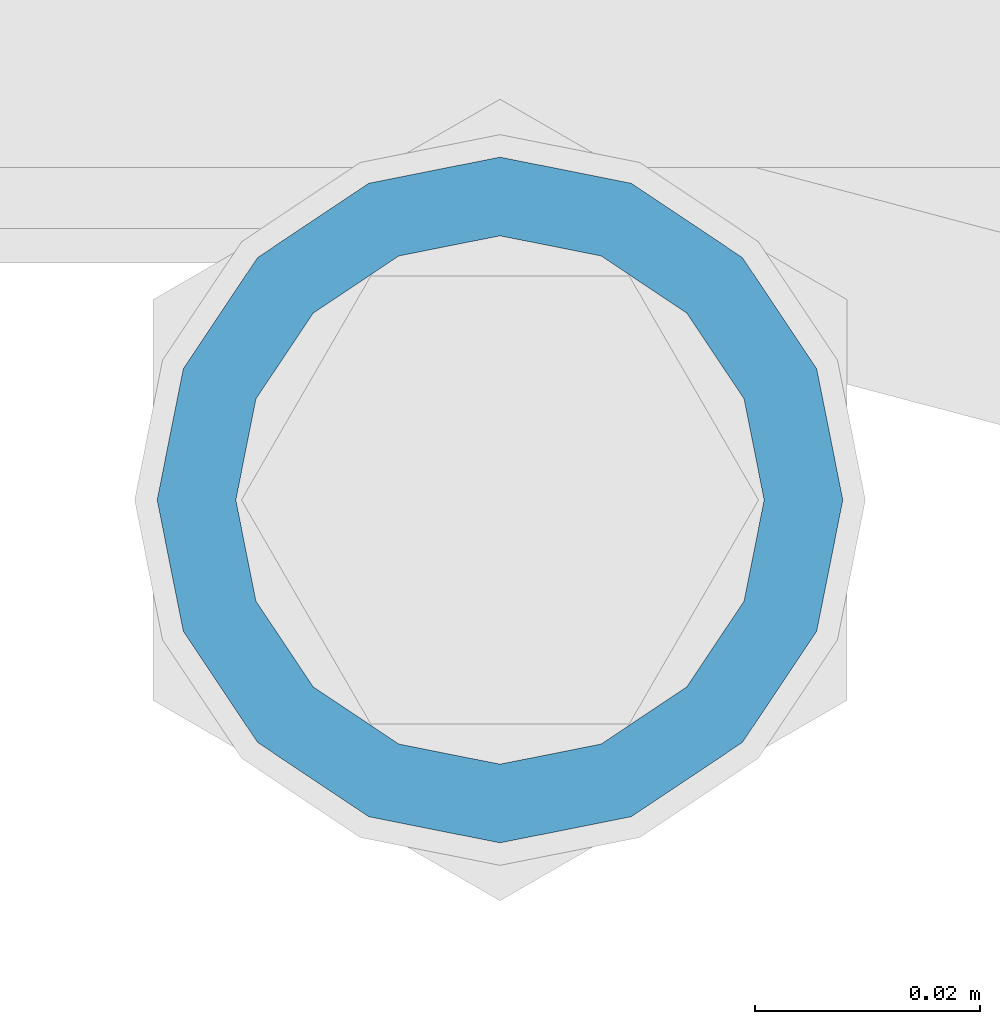
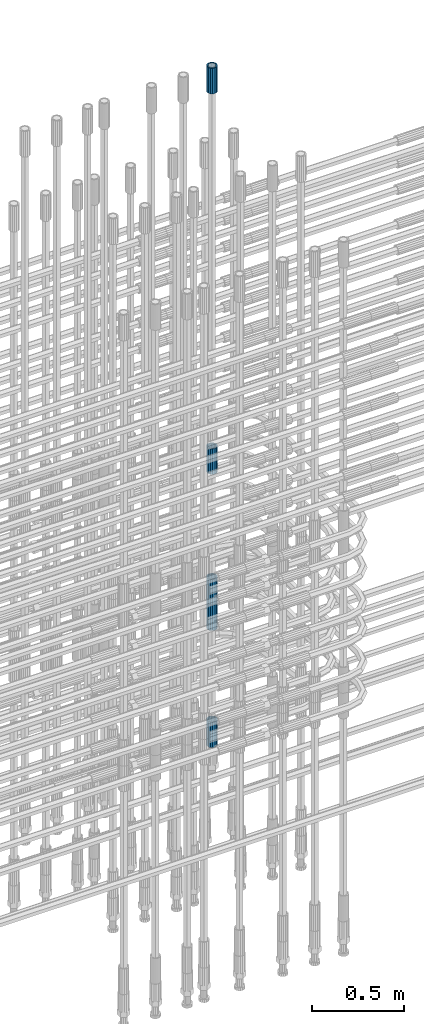
# One storey, part 73 of 119: 5 beams.
"""IFC2X3 building model written with IfcOpenShell, lengths in millimetres."""

from ifc_helpers import new_model, si_unit, frame, origin_with_axes, place, context, subcontext, project, spatial, faceted_brep, material, type_object, element, save


model = new_model("IFC2X3")

# Units and contexts
model_context = context("Model", 3, precision=1e-05, world=origin_with_axes())
body_context = subcontext(model_context, "Body", "Model", "MODEL_VIEW")
ifc_project = project(units=[si_unit("LENGTHUNIT", "METRE", prefix="MILLI"), si_unit("AREAUNIT", "SQUARE_METRE"), si_unit("VOLUMEUNIT", "CUBIC_METRE"), si_unit("MASSUNIT", "GRAM", prefix="KILO"), si_unit("TIMEUNIT", "SECOND"), si_unit("PLANEANGLEUNIT", "RADIAN"), si_unit("SOLIDANGLEUNIT", "STERADIAN"), si_unit("THERMODYNAMICTEMPERATUREUNIT", "DEGREE_CELSIUS"), si_unit("LUMINOUSINTENSITYUNIT", "LUMEN")], contexts=[model_context])

# Site, building, storey
site_placement = place(None, origin_with_axes())
site = spatial("IfcSite", under=ifc_project, at=site_placement, CompositionType="ELEMENT")
building_placement = place(site_placement, origin_with_axes())
building = spatial("IfcBuilding", under=site, at=building_placement, Name="Undefined", CompositionType="ELEMENT")
storey_placement = place(building_placement, origin_with_axes())
storey = spatial("IfcBuildingStorey", under=building, at=storey_placement, Name="Undefined", CompositionType="ELEMENT", Elevation=0.0)

# Beams
ifc_material = material(Name="STEEL/S275")
beam_type = type_object("IfcBeamType", PredefinedType="NOTDEFINED")
beam_1_placement = place(storey_placement, frame((2036305.58866833, 6206235.98579162, 20007.7168583141), z_axis=(-0.99999999999998, 1.98000110685822e-07, 0.0), x_axis=(0.0, 0.0, -1.0)))
element("IfcBeam", 1, at=beam_1_placement, inside=storey, type_object=beam_type, material=ifc_material, Name="AG40N", context=body_context, shape_type="Brep", body=[
    faceted_brep([(1.62981450557709e-09, -23.4999999990687, 0.0), (7.45058059692383e-09, -21.7111690142192, 8.99306066057534), (170.000002125278, -21.711168999318, 8.99306066022245), (170.000002127141, -23.4999999844003, -3.66071617463604e-10), (4.65661287307739e-09, -16.6170093587134, 16.6170093578889), (170.000002122484, -16.6170093440451, 16.6170093575288), (1.86264514923096e-09, -8.99306066217832, 21.7111690140277), (170.000002118759, -8.99306064750999, 21.7111690136603), (2.3283064365387e-10, 9.31322574615479e-10, 23.5), (170.000002114102, 1.28056854009628e-08, 23.4999999996485), (-6.51925802230835e-09, 8.99306065868586, 21.7111690140241), (170.00000211224, 8.99306067335419, 21.7111690136639), (-7.45058059692383e-09, 16.6170093561523, 16.6170093578853), (170.000002109446, 16.6170093708206, 16.6170093575324), (-9.31322574615479e-09, 21.711169013055, 8.99306066057534), (170.000002108514, 21.7111690277234, 8.99306066022245), (-1.16415321826935e-09, 23.5000000009313, 0.0), (170.000002108514, 23.5000000144355, -3.66071617463604e-10), (-8.38190317153931e-09, 21.7111690151505, -8.99306066059444), (170.000002110377, 21.7111690300517, -8.9930606609546), (-5.58793544769287e-09, 16.6170093598776, -16.6170093579008), (170.000002113171, 16.6170093745459, -16.6170093582609), (-9.31322574615479e-10, 8.99306066334248, -21.7111690140396), (170.000002115965, 8.99306067801081, -21.7111690143961), (2.3283064365387e-10, 9.31322574615479e-10, -23.5), (170.00000211969, 1.7927959561348e-08, -23.5000000003843), (5.58793544769287e-09, -8.99306065752171, -21.7111690140396), (170.000002123415, -8.99306064285338, -21.7111690143961), (8.38190317153931e-09, -16.6170093549881, -16.6170093579008), (170.000002125278, -16.6170093403198, -16.6170093582646), (9.31322574615479e-09, -21.7111690121237, -8.99306066059444), (170.000002127141, -21.7111689972226, -8.9930606609546), (1.11758708953857e-08, -30.4999999990687, -9.54969436861575e-12), (1.30385160446167e-08, -28.1783257392235, -11.6718446871514), (170.000002129003, -28.1783257243223, -11.6718446875116), (170.000002129935, -30.4999999841675, -3.66071617463604e-10), (1.02445483207703e-08, -21.5667568228673, -21.5667568262129), (170.000002128072, -21.566756808199, -21.5667568265694), (7.45058059692383e-09, -11.6718446831219, -28.1783257416196), (170.000002125278, -11.6718446684536, -28.1783257419834), (3.72529029846191e-09, 3.95812094211578e-09, -30.5000000000277), (170.00000211969, 1.83936208486557e-08, -30.5000000003879), (-9.31322574615479e-10, 11.6718446905725, -28.1783257416232), (170.000002115965, 11.6718447052408, -28.1783257419797), (-6.51925802230835e-09, 21.5667568286881, -21.5667568262093), (170.000002110377, 21.5667568433564, -21.5667568265694), (-9.31322574615479e-09, 28.178325742716, -11.6718446871478), (170.000002108514, 28.1783257573843, -11.6718446875079), (-1.21071934700012e-08, 30.5, -5.91171556152403e-12), (170.000002106652, 30.5000000144355, -3.62433638656512e-10), (-1.21071934700012e-08, 28.1783257401548, 11.6718446871359), (170.00000210572, 28.1783257548232, 11.6718446867794), (-1.02445483207703e-08, 21.5667568240315, 21.5667568261974), (170.000002107583, 21.566756838467, 21.5667568258409), (-7.45058059692383e-09, 11.671844684286, 28.1783257416041), (170.000002110377, 11.6718446989544, 28.178325741244), (-2.79396772384644e-09, -2.56113708019257e-09, 30.5000000000159), (170.000002114102, 1.18743628263474e-08, 30.4999999996558), (1.86264514923096e-09, -11.6718446896411, 28.1783257416114), (170.000002118759, -11.67184467474, 28.178325741244), (7.45058059692383e-09, -21.5667568275239, 21.5667568261974), (170.000002123415, -21.5667568126228, 21.5667568258373), (1.02445483207703e-08, -28.1783257415518, 11.6718446871359), (170.000002127141, -28.1783257271163, 11.6718446867794)], [[[0, 1, 2, 3]], [[1, 4, 5, 2]], [[4, 6, 7, 5]], [[6, 8, 9, 7]], [[8, 10, 11, 9]], [[10, 12, 13, 11]], [[12, 14, 15, 13]], [[14, 16, 17, 15]], [[16, 18, 19, 17]], [[18, 20, 21, 19]], [[20, 22, 23, 21]], [[22, 24, 25, 23]], [[24, 26, 27, 25]], [[26, 28, 29, 27]], [[28, 30, 31, 29]], [[30, 0, 3, 31]], [[32, 33, 34, 35]], [[33, 36, 37, 34]], [[36, 38, 39, 37]], [[38, 40, 41, 39]], [[40, 42, 43, 41]], [[42, 44, 45, 43]], [[44, 46, 47, 45]], [[46, 48, 49, 47]], [[48, 50, 51, 49]], [[50, 52, 53, 51]], [[52, 54, 55, 53]], [[54, 56, 57, 55]], [[56, 58, 59, 57]], [[58, 60, 61, 59]], [[60, 62, 63, 61]], [[62, 32, 35, 63]], [[37, 39, 41, 43, 45, 47, 49, 51, 53, 55, 57, 59, 61, 63, 35, 34], [5, 7, 9, 11, 13, 15, 17, 19, 21, 23, 25, 27, 29, 31, 3, 2]], [[62, 60, 58, 56, 54, 52, 50, 48, 46, 44, 42, 40, 38, 36, 33, 32], [30, 28, 26, 24, 22, 20, 18, 16, 14, 12, 10, 8, 6, 4, 1, 0]]]),
])
beam_2_placement = place(storey_placement, frame((2036305.58866833, 6206235.98579162, 23229.9657291637), z_axis=(1.0, 0.0, 0.0), x_axis=(0.0, 0.0, 1.0)))
element("IfcBeam", 2, at=beam_2_placement, inside=storey, type_object=beam_type, material=ifc_material, Name="AG40N", context=body_context, shape_type="Brep", body=[
    faceted_brep([(1.62981450557709e-09, -23.4999999990687, 0.0), (7.45058059692383e-09, -21.7111690142192, 8.99306066057534), (170.000002125278, -21.711168999318, 8.99306066022245), (170.000002127141, -23.4999999844003, -3.66071617463604e-10), (4.65661287307739e-09, -16.6170093587134, 16.6170093578889), (170.000002122484, -16.6170093440451, 16.6170093575288), (1.86264514923096e-09, -8.99306066217832, 21.7111690140277), (170.000002118759, -8.99306064750999, 21.7111690136603), (2.3283064365387e-10, 9.31322574615479e-10, 23.5), (170.000002114102, 1.28056854009628e-08, 23.4999999996485), (-6.51925802230835e-09, 8.99306065868586, 21.7111690140241), (170.00000211224, 8.99306067335419, 21.7111690136639), (-7.45058059692383e-09, 16.6170093561523, 16.6170093578853), (170.000002109446, 16.6170093708206, 16.6170093575324), (-9.31322574615479e-09, 21.711169013055, 8.99306066057534), (170.000002108514, 21.7111690277234, 8.99306066022245), (-1.16415321826935e-09, 23.5000000009313, 0.0), (170.000002108514, 23.5000000144355, -3.66071617463604e-10), (-8.38190317153931e-09, 21.7111690151505, -8.99306066059444), (170.000002110377, 21.7111690300517, -8.9930606609546), (-5.58793544769287e-09, 16.6170093598776, -16.6170093579008), (170.000002113171, 16.6170093745459, -16.6170093582609), (-9.31322574615479e-10, 8.99306066334248, -21.7111690140396), (170.000002115965, 8.99306067801081, -21.7111690143961), (2.3283064365387e-10, 9.31322574615479e-10, -23.5), (170.00000211969, 1.7927959561348e-08, -23.5000000003843), (5.58793544769287e-09, -8.99306065752171, -21.7111690140396), (170.000002123415, -8.99306064285338, -21.7111690143961), (8.38190317153931e-09, -16.6170093549881, -16.6170093579008), (170.000002125278, -16.6170093403198, -16.6170093582646), (9.31322574615479e-09, -21.7111690121237, -8.99306066059444), (170.000002127141, -21.7111689972226, -8.9930606609546), (1.11758708953857e-08, -30.4999999990687, -9.54969436861575e-12), (1.30385160446167e-08, -28.1783257392235, -11.6718446871514), (170.000002129003, -28.1783257243223, -11.6718446875116), (170.000002129935, -30.4999999841675, -3.66071617463604e-10), (1.02445483207703e-08, -21.5667568228673, -21.5667568262129), (170.000002128072, -21.566756808199, -21.5667568265694), (7.45058059692383e-09, -11.6718446831219, -28.1783257416196), (170.000002125278, -11.6718446684536, -28.1783257419834), (3.72529029846191e-09, 3.95812094211578e-09, -30.5000000000277), (170.00000211969, 1.83936208486557e-08, -30.5000000003879), (-9.31322574615479e-10, 11.6718446905725, -28.1783257416232), (170.000002115965, 11.6718447052408, -28.1783257419797), (-6.51925802230835e-09, 21.5667568286881, -21.5667568262093), (170.000002110377, 21.5667568433564, -21.5667568265694), (-9.31322574615479e-09, 28.178325742716, -11.6718446871478), (170.000002108514, 28.1783257573843, -11.6718446875079), (-1.21071934700012e-08, 30.5, -5.91171556152403e-12), (170.000002106652, 30.5000000144355, -3.62433638656512e-10), (-1.21071934700012e-08, 28.1783257401548, 11.6718446871359), (170.00000210572, 28.1783257548232, 11.6718446867794), (-1.02445483207703e-08, 21.5667568240315, 21.5667568261974), (170.000002107583, 21.566756838467, 21.5667568258409), (-7.45058059692383e-09, 11.671844684286, 28.1783257416041), (170.000002110377, 11.6718446989544, 28.178325741244), (-2.79396772384644e-09, -2.56113708019257e-09, 30.5000000000159), (170.000002114102, 1.18743628263474e-08, 30.4999999996558), (1.86264514923096e-09, -11.6718446896411, 28.1783257416114), (170.000002118759, -11.67184467474, 28.178325741244), (7.45058059692383e-09, -21.5667568275239, 21.5667568261974), (170.000002123415, -21.5667568126228, 21.5667568258373), (1.02445483207703e-08, -28.1783257415518, 11.6718446871359), (170.000002127141, -28.1783257271163, 11.6718446867794)], [[[0, 1, 2, 3]], [[1, 4, 5, 2]], [[4, 6, 7, 5]], [[6, 8, 9, 7]], [[8, 10, 11, 9]], [[10, 12, 13, 11]], [[12, 14, 15, 13]], [[14, 16, 17, 15]], [[16, 18, 19, 17]], [[18, 20, 21, 19]], [[20, 22, 23, 21]], [[22, 24, 25, 23]], [[24, 26, 27, 25]], [[26, 28, 29, 27]], [[28, 30, 31, 29]], [[30, 0, 3, 31]], [[32, 33, 34, 35]], [[33, 36, 37, 34]], [[36, 38, 39, 37]], [[38, 40, 41, 39]], [[40, 42, 43, 41]], [[42, 44, 45, 43]], [[44, 46, 47, 45]], [[46, 48, 49, 47]], [[48, 50, 51, 49]], [[50, 52, 53, 51]], [[52, 54, 55, 53]], [[54, 56, 57, 55]], [[56, 58, 59, 57]], [[58, 60, 61, 59]], [[60, 62, 63, 61]], [[62, 32, 35, 63]], [[37, 39, 41, 43, 45, 47, 49, 51, 53, 55, 57, 59, 61, 63, 35, 34], [5, 7, 9, 11, 13, 15, 17, 19, 21, 23, 25, 27, 29, 31, 3, 2]], [[62, 60, 58, 56, 54, 52, 50, 48, 46, 44, 42, 40, 38, 36, 33, 32], [30, 28, 26, 24, 22, 20, 18, 16, 14, 12, 10, 8, 6, 4, 1, 0]]]),
])
beam_3_placement = place(storey_placement, frame((2036305.58866833, 6206235.98579162, 20704.6057291637), z_axis=(1.0, 0.0, 0.0), x_axis=(0.0, 0.0, 1.0)))
element("IfcBeam", 3, at=beam_3_placement, inside=storey, type_object=beam_type, material=ifc_material, Name="AG40N", context=body_context, shape_type="Brep", body=[
    faceted_brep([(1.62981450557709e-09, -23.4999999990687, 0.0), (7.45058059692383e-09, -21.7111690142192, 8.99306066057534), (170.000002125278, -21.711168999318, 8.99306066022245), (170.000002127141, -23.4999999844003, -3.66071617463604e-10), (4.65661287307739e-09, -16.6170093587134, 16.6170093578889), (170.000002122484, -16.6170093440451, 16.6170093575288), (1.86264514923096e-09, -8.99306066217832, 21.7111690140277), (170.000002118759, -8.99306064750999, 21.7111690136603), (2.3283064365387e-10, 9.31322574615479e-10, 23.5), (170.000002114102, 1.28056854009628e-08, 23.4999999996485), (-6.51925802230835e-09, 8.99306065868586, 21.7111690140241), (170.00000211224, 8.99306067335419, 21.7111690136639), (-7.45058059692383e-09, 16.6170093561523, 16.6170093578853), (170.000002109446, 16.6170093708206, 16.6170093575324), (-9.31322574615479e-09, 21.711169013055, 8.99306066057534), (170.000002108514, 21.7111690277234, 8.99306066022245), (-1.16415321826935e-09, 23.5000000009313, 0.0), (170.000002108514, 23.5000000144355, -3.66071617463604e-10), (-8.38190317153931e-09, 21.7111690151505, -8.99306066059444), (170.000002110377, 21.7111690300517, -8.9930606609546), (-5.58793544769287e-09, 16.6170093598776, -16.6170093579008), (170.000002113171, 16.6170093745459, -16.6170093582609), (-9.31322574615479e-10, 8.99306066334248, -21.7111690140396), (170.000002115965, 8.99306067801081, -21.7111690143961), (2.3283064365387e-10, 9.31322574615479e-10, -23.5), (170.00000211969, 1.7927959561348e-08, -23.5000000003843), (5.58793544769287e-09, -8.99306065752171, -21.7111690140396), (170.000002123415, -8.99306064285338, -21.7111690143961), (8.38190317153931e-09, -16.6170093549881, -16.6170093579008), (170.000002125278, -16.6170093403198, -16.6170093582646), (9.31322574615479e-09, -21.7111690121237, -8.99306066059444), (170.000002127141, -21.7111689972226, -8.9930606609546), (1.11758708953857e-08, -30.4999999990687, -9.54969436861575e-12), (1.30385160446167e-08, -28.1783257392235, -11.6718446871514), (170.000002129003, -28.1783257243223, -11.6718446875116), (170.000002129935, -30.4999999841675, -3.66071617463604e-10), (1.02445483207703e-08, -21.5667568228673, -21.5667568262129), (170.000002128072, -21.566756808199, -21.5667568265694), (7.45058059692383e-09, -11.6718446831219, -28.1783257416196), (170.000002125278, -11.6718446684536, -28.1783257419834), (3.72529029846191e-09, 3.95812094211578e-09, -30.5000000000277), (170.00000211969, 1.83936208486557e-08, -30.5000000003879), (-9.31322574615479e-10, 11.6718446905725, -28.1783257416232), (170.000002115965, 11.6718447052408, -28.1783257419797), (-6.51925802230835e-09, 21.5667568286881, -21.5667568262093), (170.000002110377, 21.5667568433564, -21.5667568265694), (-9.31322574615479e-09, 28.178325742716, -11.6718446871478), (170.000002108514, 28.1783257573843, -11.6718446875079), (-1.21071934700012e-08, 30.5, -5.91171556152403e-12), (170.000002106652, 30.5000000144355, -3.62433638656512e-10), (-1.21071934700012e-08, 28.1783257401548, 11.6718446871359), (170.00000210572, 28.1783257548232, 11.6718446867794), (-1.02445483207703e-08, 21.5667568240315, 21.5667568261974), (170.000002107583, 21.566756838467, 21.5667568258409), (-7.45058059692383e-09, 11.671844684286, 28.1783257416041), (170.000002110377, 11.6718446989544, 28.178325741244), (-2.79396772384644e-09, -2.56113708019257e-09, 30.5000000000159), (170.000002114102, 1.18743628263474e-08, 30.4999999996558), (1.86264514923096e-09, -11.6718446896411, 28.1783257416114), (170.000002118759, -11.67184467474, 28.178325741244), (7.45058059692383e-09, -21.5667568275239, 21.5667568261974), (170.000002123415, -21.5667568126228, 21.5667568258373), (1.02445483207703e-08, -28.1783257415518, 11.6718446871359), (170.000002127141, -28.1783257271163, 11.6718446867794)], [[[0, 1, 2, 3]], [[1, 4, 5, 2]], [[4, 6, 7, 5]], [[6, 8, 9, 7]], [[8, 10, 11, 9]], [[10, 12, 13, 11]], [[12, 14, 15, 13]], [[14, 16, 17, 15]], [[16, 18, 19, 17]], [[18, 20, 21, 19]], [[20, 22, 23, 21]], [[22, 24, 25, 23]], [[24, 26, 27, 25]], [[26, 28, 29, 27]], [[28, 30, 31, 29]], [[30, 0, 3, 31]], [[32, 33, 34, 35]], [[33, 36, 37, 34]], [[36, 38, 39, 37]], [[38, 40, 41, 39]], [[40, 42, 43, 41]], [[42, 44, 45, 43]], [[44, 46, 47, 45]], [[46, 48, 49, 47]], [[48, 50, 51, 49]], [[50, 52, 53, 51]], [[52, 54, 55, 53]], [[54, 56, 57, 55]], [[56, 58, 59, 57]], [[58, 60, 61, 59]], [[60, 62, 63, 61]], [[62, 32, 35, 63]], [[37, 39, 41, 43, 45, 47, 49, 51, 53, 55, 57, 59, 61, 63, 35, 34], [5, 7, 9, 11, 13, 15, 17, 19, 21, 23, 25, 27, 29, 31, 3, 2]], [[62, 60, 58, 56, 54, 52, 50, 48, 46, 44, 42, 40, 38, 36, 33, 32], [30, 28, 26, 24, 22, 20, 18, 16, 14, 12, 10, 8, 6, 4, 1, 0]]]),
])
beam_4_placement = place(storey_placement, frame((2036305.58866833, 6206235.98579162, 19667.7157291637), z_axis=(1.0, 0.0, 0.0), x_axis=(0.0, 0.0, 1.0)))
element("IfcBeam", 4, at=beam_4_placement, inside=storey, type_object=beam_type, material=ifc_material, Name="AG40N", context=body_context, shape_type="Brep", body=[
    faceted_brep([(1.62981450557709e-09, -23.4999999990687, 0.0), (7.45058059692383e-09, -21.7111690142192, 8.99306066057534), (170.000002125278, -21.711168999318, 8.99306066022245), (170.000002127141, -23.4999999844003, -3.66071617463604e-10), (4.65661287307739e-09, -16.6170093587134, 16.6170093578889), (170.000002122484, -16.6170093440451, 16.6170093575288), (1.86264514923096e-09, -8.99306066217832, 21.7111690140277), (170.000002118759, -8.99306064750999, 21.7111690136603), (2.3283064365387e-10, 9.31322574615479e-10, 23.5), (170.000002114102, 1.28056854009628e-08, 23.4999999996485), (-6.51925802230835e-09, 8.99306065868586, 21.7111690140241), (170.00000211224, 8.99306067335419, 21.7111690136639), (-7.45058059692383e-09, 16.6170093561523, 16.6170093578853), (170.000002109446, 16.6170093708206, 16.6170093575324), (-9.31322574615479e-09, 21.711169013055, 8.99306066057534), (170.000002108514, 21.7111690277234, 8.99306066022245), (-1.16415321826935e-09, 23.5000000009313, 0.0), (170.000002108514, 23.5000000144355, -3.66071617463604e-10), (-8.38190317153931e-09, 21.7111690151505, -8.99306066059444), (170.000002110377, 21.7111690300517, -8.9930606609546), (-5.58793544769287e-09, 16.6170093598776, -16.6170093579008), (170.000002113171, 16.6170093745459, -16.6170093582609), (-9.31322574615479e-10, 8.99306066334248, -21.7111690140396), (170.000002115965, 8.99306067801081, -21.7111690143961), (2.3283064365387e-10, 9.31322574615479e-10, -23.5), (170.00000211969, 1.7927959561348e-08, -23.5000000003843), (5.58793544769287e-09, -8.99306065752171, -21.7111690140396), (170.000002123415, -8.99306064285338, -21.7111690143961), (8.38190317153931e-09, -16.6170093549881, -16.6170093579008), (170.000002125278, -16.6170093403198, -16.6170093582646), (9.31322574615479e-09, -21.7111690121237, -8.99306066059444), (170.000002127141, -21.7111689972226, -8.9930606609546), (1.11758708953857e-08, -30.4999999990687, -9.54969436861575e-12), (1.30385160446167e-08, -28.1783257392235, -11.6718446871514), (170.000002129003, -28.1783257243223, -11.6718446875116), (170.000002129935, -30.4999999841675, -3.66071617463604e-10), (1.02445483207703e-08, -21.5667568228673, -21.5667568262129), (170.000002128072, -21.566756808199, -21.5667568265694), (7.45058059692383e-09, -11.6718446831219, -28.1783257416196), (170.000002125278, -11.6718446684536, -28.1783257419834), (3.72529029846191e-09, 3.95812094211578e-09, -30.5000000000277), (170.00000211969, 1.83936208486557e-08, -30.5000000003879), (-9.31322574615479e-10, 11.6718446905725, -28.1783257416232), (170.000002115965, 11.6718447052408, -28.1783257419797), (-6.51925802230835e-09, 21.5667568286881, -21.5667568262093), (170.000002110377, 21.5667568433564, -21.5667568265694), (-9.31322574615479e-09, 28.178325742716, -11.6718446871478), (170.000002108514, 28.1783257573843, -11.6718446875079), (-1.21071934700012e-08, 30.5, -5.91171556152403e-12), (170.000002106652, 30.5000000144355, -3.62433638656512e-10), (-1.21071934700012e-08, 28.1783257401548, 11.6718446871359), (170.00000210572, 28.1783257548232, 11.6718446867794), (-1.02445483207703e-08, 21.5667568240315, 21.5667568261974), (170.000002107583, 21.566756838467, 21.5667568258409), (-7.45058059692383e-09, 11.671844684286, 28.1783257416041), (170.000002110377, 11.6718446989544, 28.178325741244), (-2.79396772384644e-09, -2.56113708019257e-09, 30.5000000000159), (170.000002114102, 1.18743628263474e-08, 30.4999999996558), (1.86264514923096e-09, -11.6718446896411, 28.1783257416114), (170.000002118759, -11.67184467474, 28.178325741244), (7.45058059692383e-09, -21.5667568275239, 21.5667568261974), (170.000002123415, -21.5667568126228, 21.5667568258373), (1.02445483207703e-08, -28.1783257415518, 11.6718446871359), (170.000002127141, -28.1783257271163, 11.6718446867794)], [[[0, 1, 2, 3]], [[1, 4, 5, 2]], [[4, 6, 7, 5]], [[6, 8, 9, 7]], [[8, 10, 11, 9]], [[10, 12, 13, 11]], [[12, 14, 15, 13]], [[14, 16, 17, 15]], [[16, 18, 19, 17]], [[18, 20, 21, 19]], [[20, 22, 23, 21]], [[22, 24, 25, 23]], [[24, 26, 27, 25]], [[26, 28, 29, 27]], [[28, 30, 31, 29]], [[30, 0, 3, 31]], [[32, 33, 34, 35]], [[33, 36, 37, 34]], [[36, 38, 39, 37]], [[38, 40, 41, 39]], [[40, 42, 43, 41]], [[42, 44, 45, 43]], [[44, 46, 47, 45]], [[46, 48, 49, 47]], [[48, 50, 51, 49]], [[50, 52, 53, 51]], [[52, 54, 55, 53]], [[54, 56, 57, 55]], [[56, 58, 59, 57]], [[58, 60, 61, 59]], [[60, 62, 63, 61]], [[62, 32, 35, 63]], [[37, 39, 41, 43, 45, 47, 49, 51, 53, 55, 57, 59, 61, 63, 35, 34], [5, 7, 9, 11, 13, 15, 17, 19, 21, 23, 25, 27, 29, 31, 3, 2]], [[62, 60, 58, 56, 54, 52, 50, 48, 46, 44, 42, 40, 38, 36, 33, 32], [30, 28, 26, 24, 22, 20, 18, 16, 14, 12, 10, 8, 6, 4, 1, 0]]]),
])
beam_5_placement = place(storey_placement, frame((2036305.58866833, 6206235.98579162, 19060.9668583146), z_axis=(-0.99999999999998, 1.98000110685822e-07, 0.0), x_axis=(0.0, 0.0, -1.0)))
element("IfcBeam", 5, at=beam_5_placement, inside=storey, type_object=beam_type, material=ifc_material, Name="AG40N", context=body_context, shape_type="Brep", body=[
    faceted_brep([(1.62981450557709e-09, -23.4999999990687, 0.0), (7.45058059692383e-09, -21.7111690142192, 8.99306066057534), (170.000002125278, -21.711168999318, 8.99306066022245), (170.000002127141, -23.4999999844003, -3.66071617463604e-10), (4.65661287307739e-09, -16.6170093587134, 16.6170093578889), (170.000002122484, -16.6170093440451, 16.6170093575288), (1.86264514923096e-09, -8.99306066217832, 21.7111690140277), (170.000002118759, -8.99306064750999, 21.7111690136603), (2.3283064365387e-10, 9.31322574615479e-10, 23.5), (170.000002114102, 1.28056854009628e-08, 23.4999999996485), (-6.51925802230835e-09, 8.99306065868586, 21.7111690140241), (170.00000211224, 8.99306067335419, 21.7111690136639), (-7.45058059692383e-09, 16.6170093561523, 16.6170093578853), (170.000002109446, 16.6170093708206, 16.6170093575324), (-9.31322574615479e-09, 21.711169013055, 8.99306066057534), (170.000002108514, 21.7111690277234, 8.99306066022245), (-1.16415321826935e-09, 23.5000000009313, 0.0), (170.000002108514, 23.5000000144355, -3.66071617463604e-10), (-8.38190317153931e-09, 21.7111690151505, -8.99306066059444), (170.000002110377, 21.7111690300517, -8.9930606609546), (-5.58793544769287e-09, 16.6170093598776, -16.6170093579008), (170.000002113171, 16.6170093745459, -16.6170093582609), (-9.31322574615479e-10, 8.99306066334248, -21.7111690140396), (170.000002115965, 8.99306067801081, -21.7111690143961), (2.3283064365387e-10, 9.31322574615479e-10, -23.5), (170.00000211969, 1.7927959561348e-08, -23.5000000003843), (5.58793544769287e-09, -8.99306065752171, -21.7111690140396), (170.000002123415, -8.99306064285338, -21.7111690143961), (8.38190317153931e-09, -16.6170093549881, -16.6170093579008), (170.000002125278, -16.6170093403198, -16.6170093582646), (9.31322574615479e-09, -21.7111690121237, -8.99306066059444), (170.000002127141, -21.7111689972226, -8.9930606609546), (1.11758708953857e-08, -30.4999999990687, -9.54969436861575e-12), (1.30385160446167e-08, -28.1783257392235, -11.6718446871514), (170.000002129003, -28.1783257243223, -11.6718446875116), (170.000002129935, -30.4999999841675, -3.66071617463604e-10), (1.02445483207703e-08, -21.5667568228673, -21.5667568262129), (170.000002128072, -21.566756808199, -21.5667568265694), (7.45058059692383e-09, -11.6718446831219, -28.1783257416196), (170.000002125278, -11.6718446684536, -28.1783257419834), (3.72529029846191e-09, 3.95812094211578e-09, -30.5000000000277), (170.00000211969, 1.83936208486557e-08, -30.5000000003879), (-9.31322574615479e-10, 11.6718446905725, -28.1783257416232), (170.000002115965, 11.6718447052408, -28.1783257419797), (-6.51925802230835e-09, 21.5667568286881, -21.5667568262093), (170.000002110377, 21.5667568433564, -21.5667568265694), (-9.31322574615479e-09, 28.178325742716, -11.6718446871478), (170.000002108514, 28.1783257573843, -11.6718446875079), (-1.21071934700012e-08, 30.5, -5.91171556152403e-12), (170.000002106652, 30.5000000144355, -3.62433638656512e-10), (-1.21071934700012e-08, 28.1783257401548, 11.6718446871359), (170.00000210572, 28.1783257548232, 11.6718446867794), (-1.02445483207703e-08, 21.5667568240315, 21.5667568261974), (170.000002107583, 21.566756838467, 21.5667568258409), (-7.45058059692383e-09, 11.671844684286, 28.1783257416041), (170.000002110377, 11.6718446989544, 28.178325741244), (-2.79396772384644e-09, -2.56113708019257e-09, 30.5000000000159), (170.000002114102, 1.18743628263474e-08, 30.4999999996558), (1.86264514923096e-09, -11.6718446896411, 28.1783257416114), (170.000002118759, -11.67184467474, 28.178325741244), (7.45058059692383e-09, -21.5667568275239, 21.5667568261974), (170.000002123415, -21.5667568126228, 21.5667568258373), (1.02445483207703e-08, -28.1783257415518, 11.6718446871359), (170.000002127141, -28.1783257271163, 11.6718446867794)], [[[0, 1, 2, 3]], [[1, 4, 5, 2]], [[4, 6, 7, 5]], [[6, 8, 9, 7]], [[8, 10, 11, 9]], [[10, 12, 13, 11]], [[12, 14, 15, 13]], [[14, 16, 17, 15]], [[16, 18, 19, 17]], [[18, 20, 21, 19]], [[20, 22, 23, 21]], [[22, 24, 25, 23]], [[24, 26, 27, 25]], [[26, 28, 29, 27]], [[28, 30, 31, 29]], [[30, 0, 3, 31]], [[32, 33, 34, 35]], [[33, 36, 37, 34]], [[36, 38, 39, 37]], [[38, 40, 41, 39]], [[40, 42, 43, 41]], [[42, 44, 45, 43]], [[44, 46, 47, 45]], [[46, 48, 49, 47]], [[48, 50, 51, 49]], [[50, 52, 53, 51]], [[52, 54, 55, 53]], [[54, 56, 57, 55]], [[56, 58, 59, 57]], [[58, 60, 61, 59]], [[60, 62, 63, 61]], [[62, 32, 35, 63]], [[37, 39, 41, 43, 45, 47, 49, 51, 53, 55, 57, 59, 61, 63, 35, 34], [5, 7, 9, 11, 13, 15, 17, 19, 21, 23, 25, 27, 29, 31, 3, 2]], [[62, 60, 58, 56, 54, 52, 50, 48, 46, 44, 42, 40, 38, 36, 33, 32], [30, 28, 26, 24, 22, 20, 18, 16, 14, 12, 10, 8, 6, 4, 1, 0]]]),
])

save(model, "model.ifc")
